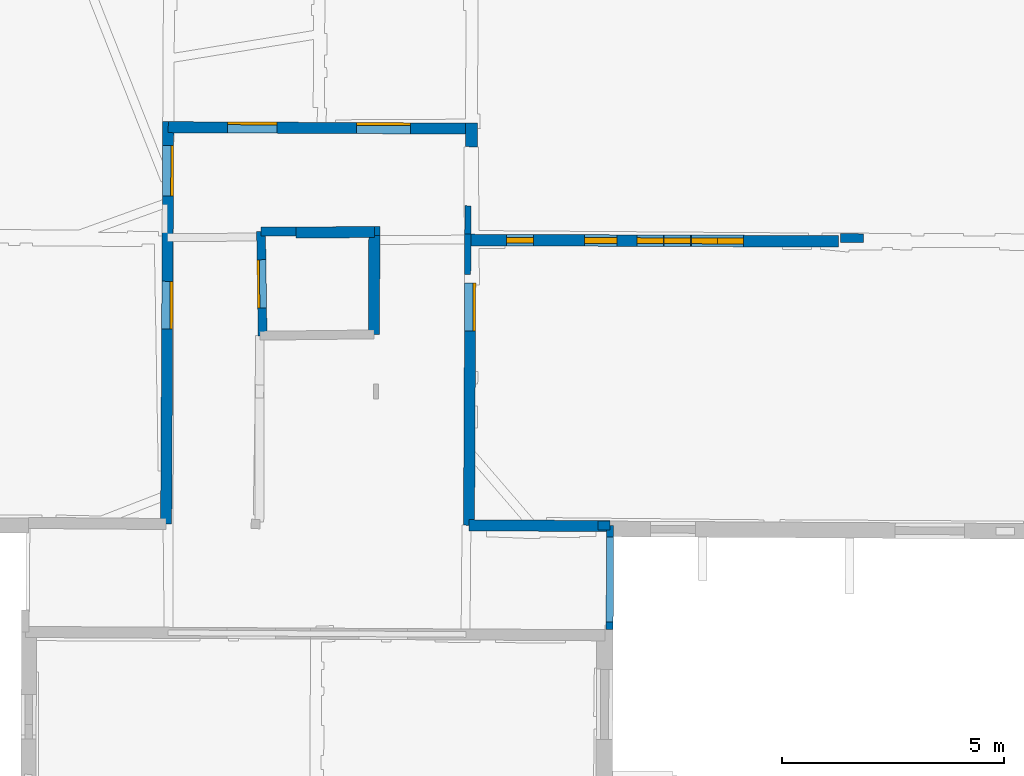
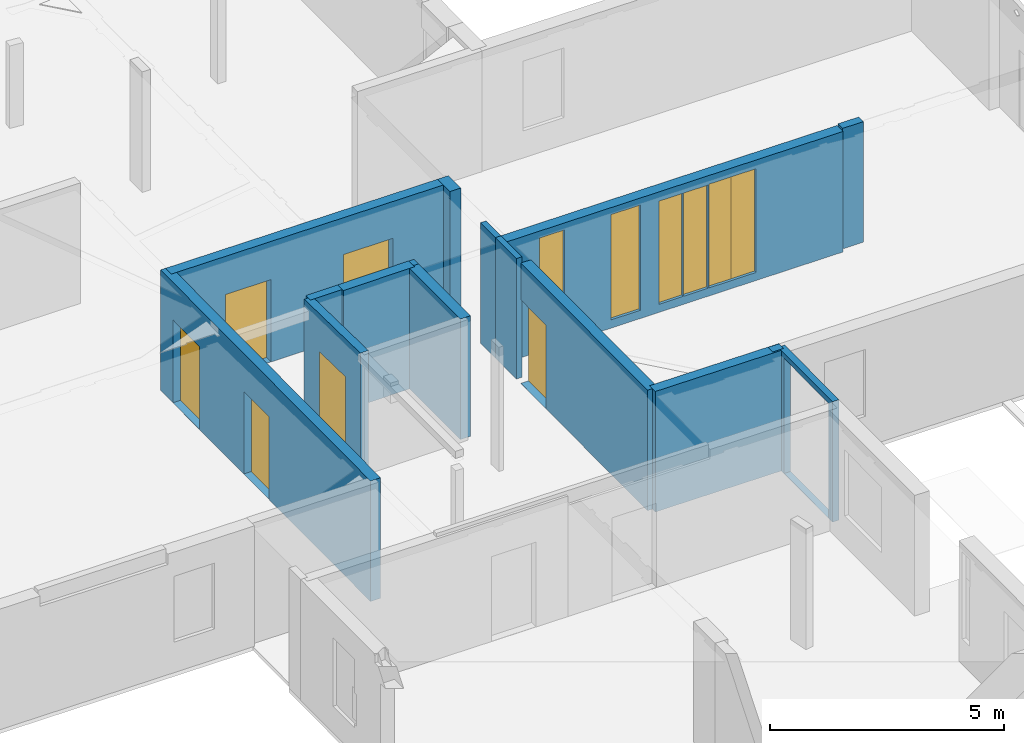
# One storey, part 7 of 14: 16 walls, 6 doors, 6 windows, 13 openings.
"""IFC2X3 building model written with IfcOpenShell, lengths in metres."""

from ifc_helpers import new_model, entity, si_unit, converted_unit, derived_unit, direction, frame, frame_2d, origin, origin_2d_with_axis, place, context, subcontext, project, spatial, polyline, rectangle, outline, extrude, source, transform, mapped, material, layer, layer_set, layer_usage, type_object, type_shapes, element, fill, save


model = new_model("IFC2X3")

# Units and contexts
model_context = context("Model", 3, precision=1e-05, world=origin(), true_north=direction((0.0, 1.0)))
body_context = subcontext(model_context, "Body", "Model", "MODEL_VIEW")
ifc_project = project(units=[si_unit("LENGTHUNIT", "METRE"), si_unit("AREAUNIT", "SQUARE_METRE"), si_unit("VOLUMEUNIT", "CUBIC_METRE"), converted_unit("PLANEANGLEUNIT", "DEGREE", entity("IfcRatioMeasure", 0.0174532925199433), si_unit("PLANEANGLEUNIT", "RADIAN"), dimensions=[0, 0, 0, 0, 0, 0, 0]), si_unit("MASSUNIT", "GRAM", prefix="KILO"), derived_unit("MASSDENSITYUNIT", [(si_unit("MASSUNIT", "GRAM", prefix="KILO"), 1), (si_unit("LENGTHUNIT", "METRE"), -3)]), derived_unit("MOMENTOFINERTIAUNIT", [(si_unit("LENGTHUNIT", "METRE"), 4)]), si_unit("TIMEUNIT", "SECOND"), si_unit("FREQUENCYUNIT", "HERTZ"), si_unit("THERMODYNAMICTEMPERATUREUNIT", "DEGREE_CELSIUS"), derived_unit("THERMALTRANSMITTANCEUNIT", [(si_unit("MASSUNIT", "GRAM", prefix="KILO"), 1), (si_unit("THERMODYNAMICTEMPERATUREUNIT", "KELVIN"), -1), (si_unit("TIMEUNIT", "SECOND"), -3)]), derived_unit("VOLUMETRICFLOWRATEUNIT", [(si_unit("LENGTHUNIT", "METRE"), 3), (si_unit("TIMEUNIT", "SECOND"), -1)]), si_unit("ELECTRICCURRENTUNIT", "AMPERE"), si_unit("ELECTRICVOLTAGEUNIT", "VOLT"), si_unit("POWERUNIT", "WATT"), si_unit("FORCEUNIT", "NEWTON", prefix="KILO"), si_unit("ILLUMINANCEUNIT", "LUX"), si_unit("LUMINOUSFLUXUNIT", "LUMEN"), si_unit("LUMINOUSINTENSITYUNIT", "CANDELA"), derived_unit("USERDEFINED", [(si_unit("MASSUNIT", "GRAM", prefix="KILO"), -1), (si_unit("LENGTHUNIT", "METRE"), -2), (si_unit("TIMEUNIT", "SECOND"), 3), (si_unit("LUMINOUSFLUXUNIT", "LUMEN"), 1)]), derived_unit("LINEARVELOCITYUNIT", [(si_unit("LENGTHUNIT", "METRE"), 1), (si_unit("TIMEUNIT", "SECOND"), -1)]), si_unit("PRESSUREUNIT", "PASCAL"), derived_unit("USERDEFINED", [(si_unit("LENGTHUNIT", "METRE"), -2), (si_unit("MASSUNIT", "GRAM", prefix="KILO"), 1), (si_unit("TIMEUNIT", "SECOND"), -2)]), derived_unit("LINEARFORCEUNIT", [(si_unit("MASSUNIT", "GRAM", prefix="KILO"), 1), (si_unit("LENGTHUNIT", "METRE"), 1), (si_unit("TIMEUNIT", "SECOND"), -2), (si_unit("LENGTHUNIT", "METRE"), -1)]), derived_unit("PLANARFORCEUNIT", [(si_unit("MASSUNIT", "GRAM", prefix="KILO"), 1), (si_unit("LENGTHUNIT", "METRE"), 1), (si_unit("TIMEUNIT", "SECOND"), -2), (si_unit("LENGTHUNIT", "METRE"), -2)])], contexts=[model_context])

# Site, building, storey
placement = place(None, origin())
site = spatial("IfcSite", under=ifc_project, at=placement, CompositionType="ELEMENT")
building = spatial("IfcBuilding", under=site, at=placement, CompositionType="ELEMENT")
storey_placement = place(placement, frame((0.0, 0.0, 8.83152770996094)))
storey = spatial("IfcBuildingStorey", under=building, at=storey_placement, Name="Level 4", CompositionType="ELEMENT", Elevation=8.83152770996094)

# Wall, openings, doors
ifc_material_1 = material(Name="Default wall")
ifc_layer_1 = layer(ifc_material_1, 0.25)
ifc_layer_set_1 = layer_set([ifc_layer_1], Name="wall_thickness_0.2500")
ifc_layer_usage_1 = layer_usage(ifc_layer_set_1, "AXIS2", "POSITIVE", -0.125)
wall_type_1 = type_object("IfcWallType", Name="wall_thickness_0.2500", PredefinedType="STANDARD", material=ifc_layer_set_1)
wall_1_placement = place(storey_placement, frame((2.97993654286292, 60.15967701383, 0.0), z_axis=(0.0, 0.0, 1.0), x_axis=(0.999988670407602, -0.00476015298446692, 0.0)))
wall_1 = element("IfcWallStandardCase", 1, at=wall_1_placement, inside=storey, type_object=wall_type_1, material=ifc_layer_usage_1, Name="Wall:388", ObjectType="Wall", context=body_context, shape_type="SweptSolid", body=[
    extrude(outline(polyline([(6.82937086344439, -0.125), (6.82937086344439, 0.125), (0.0, 0.125), (0.0, -0.125), (6.82937086344439, -0.125)])), origin(), (0.0, 0.0, 1.0), 3.14668312072754),
])
opening_1_placement = place(wall_1_placement, frame((1.33312031191429, -0.125, 0.00547218322753906)))
opening_1 = element("IfcOpeningElement", 2, at=opening_1_placement, cuts=wall_1, Name="Opening : 1120 x 2145 : 311", ObjectType="Opening", context=body_context, shape_type="SweptSolid", body=[
    extrude(rectangle(XDim=1.12, YDim=2.145, at=frame_2d((1.0725, 0.56), x_axis=(0.0, 1.0))), frame((0.0, 0.0, 0.0), z_axis=(0.0, 1.0, 0.0), x_axis=(0.0, 0.0, 1.0)), (0.0, 0.0, 1.0), 0.25),
])
opening_2_placement = place(wall_1_placement, frame((4.24312071748149, -0.125, 0.00547218322753906)))
opening_2 = element("IfcOpeningElement", 3, at=opening_2_placement, cuts=wall_1, Name="Opening : 1210 x 2180 : 312", ObjectType="Opening", context=body_context, shape_type="SweptSolid", body=[
    extrude(rectangle(XDim=1.21, YDim=2.18, at=frame_2d((1.09, 0.605), x_axis=(0.0, 1.0))), frame((0.0, 0.0, 0.0), z_axis=(0.0, 1.0, 0.0), x_axis=(0.0, 0.0, 1.0)), (0.0, 0.0, 1.0), 0.25),
])
ifc_material_2 = material(Name="Door Panel")
door_style_1 = type_object("IfcDoorStyle", Name="Door : 1120 x 2145mm", ConstructionType="NOTDEFINED", OperationType="SINGLE_SWING_RIGHT", ParameterTakesPrecedence=False, Sizeable=False, material=ifc_material_2)
shared_shape_1 = source(origin(), body_context, "Body", "SweptSolid", [
    extrude(rectangle(XDim=0.0625, YDim=1.12, at=origin_2d_with_axis()), frame((0.56, 0.21875, 0.0), z_axis=(0.0, 0.0, 1.0), x_axis=(0.0, 1.0, 0.0)), (0.0, 0.0, 1.0), 2.145),
])
type_shapes(door_style_1, [shared_shape_1])
door_1_placement = place(opening_1_placement, origin())
door_1 = element("IfcDoor", 4, at=door_1_placement, inside=storey, type_object=door_style_1, Name="Door : 1120 x 2145mm : 59", ObjectType="Door : 1120 x 2145mm", OverallHeight=2.145, OverallWidth=1.12, context=body_context, shape_type="MappedRepresentation", body=[
    mapped(shared_shape_1, transform((0.0, 0.0, 0.0), scale=1.0)),
])
fill(opening_1, door_1)
door_style_2 = type_object("IfcDoorStyle", Name="Door : 1210 x 2180mm", ConstructionType="NOTDEFINED", OperationType="SINGLE_SWING_RIGHT", ParameterTakesPrecedence=False, Sizeable=False, material=ifc_material_2)
shared_shape_2 = source(origin(), body_context, "Body", "SweptSolid", [
    extrude(rectangle(XDim=0.0625, YDim=1.21, at=origin_2d_with_axis()), frame((0.605, 0.21875, 0.0), z_axis=(0.0, 0.0, 1.0), x_axis=(0.0, 1.0, 0.0)), (0.0, 0.0, 1.0), 2.18),
])
type_shapes(door_style_2, [shared_shape_2])
door_2_placement = place(opening_2_placement, origin())
door_2 = element("IfcDoor", 5, at=door_2_placement, inside=storey, type_object=door_style_2, Name="Door : 1210 x 2180mm : 60", ObjectType="Door : 1210 x 2180mm", OverallHeight=2.18, OverallWidth=1.21, context=body_context, shape_type="MappedRepresentation", body=[
    mapped(shared_shape_2, transform((0.0, 0.0, 0.0), scale=1.0)),
])
fill(opening_2, door_2)

# Wall
wall_2_placement = place(storey_placement, frame((9.75449950184054, 51.1931051464157, 0.0), z_axis=(0.0, 0.0, 1.0), x_axis=(0.999980348594832, -0.00626916455027329, 0.0)))
element("IfcWallStandardCase", 6, at=wall_2_placement, inside=storey, type_object=wall_type_1, material=ifc_layer_usage_1, Name="Wall:418", ObjectType="Wall", context=body_context, shape_type="SweptSolid", body=[
    extrude(outline(polyline([(3.17872953498346, -0.125), (3.17872953498346, 0.125), (0.0, 0.125), (0.0, -0.125), (3.17872953498346, -0.125)])), origin(), (0.0, 0.0, 1.0), 3.14668312072754),
])

# Wall, opening, door
wall_3_placement = place(storey_placement, frame((9.7818454333714, 56.6549451362914, 0.0), z_axis=(0.0, 0.0, 1.0), x_axis=(-0.00500660722327375, -0.999987466863516, 0.0)))
wall_3 = element("IfcWallStandardCase", 7, at=wall_3_placement, inside=storey, type_object=wall_type_1, material=ifc_layer_usage_1, Name="Wall:455", ObjectType="Wall", context=body_context, shape_type="SweptSolid", body=[
    extrude(outline(polyline([(5.461913852861, -0.125), (5.461913852861, 0.125), (0.0, 0.125), (0.0, -0.125), (5.461913852861, -0.125)])), origin(), (0.0, 0.0, 1.0), 3.14668312072754),
])
opening_3_placement = place(wall_3_placement, frame((-2.16926929090056e-08, -0.125, 0.00547218322753906)))
opening_3 = element("IfcOpeningElement", 8, at=opening_3_placement, cuts=wall_3, Name="Opening : 1085 x 2180 : 351", ObjectType="Opening", context=body_context, shape_type="SweptSolid", body=[
    extrude(rectangle(XDim=1.085, YDim=2.18, at=frame_2d((1.09, 0.5425), x_axis=(0.0, 1.0))), frame((0.0, 0.0, 0.0), z_axis=(0.0, 1.0, 0.0), x_axis=(0.0, 0.0, 1.0)), (0.0, 0.0, 1.0), 0.25),
])
door_style_3 = type_object("IfcDoorStyle", Name="Door : 1085 x 2180mm", ConstructionType="NOTDEFINED", OperationType="SINGLE_SWING_RIGHT", ParameterTakesPrecedence=False, Sizeable=False, material=ifc_material_2)
shared_shape_3 = source(origin(), body_context, "Body", "SweptSolid", [
    extrude(rectangle(XDim=0.0625, YDim=1.085, at=origin_2d_with_axis()), frame((0.5425, 0.21875, 0.0), z_axis=(0.0, 0.0, 1.0), x_axis=(0.0, 1.0, 0.0)), (0.0, 0.0, 1.0), 2.18),
])
type_shapes(door_style_3, [shared_shape_3])
door_3_placement = place(opening_3_placement, origin())
door_3 = element("IfcDoor", 9, at=door_3_placement, inside=storey, type_object=door_style_3, Name="Door : 1085 x 2180mm : 67", ObjectType="Door : 1085 x 2180mm", OverallHeight=2.18, OverallWidth=1.085, context=body_context, shape_type="MappedRepresentation", body=[
    mapped(shared_shape_3, transform((0.0, 0.0, 0.0), scale=1.0)),
])
fill(opening_3, door_3)

# Wall
wall_4_placement = place(storey_placement, frame((5.85365022321484, 57.7850229386726, 0.0), z_axis=(0.0, 0.0, 1.0), x_axis=(0.99997111015831, 0.00760123994863184, 0.0)))
element("IfcWallStandardCase", 10, at=wall_4_placement, inside=storey, type_object=wall_type_1, material=ifc_layer_usage_1, Name="Wall:470", ObjectType="Wall", context=body_context, shape_type="SweptSolid", body=[
    extrude(outline(polyline([(1.76802450095209, -0.125), (1.76802450095209, 0.125), (0.0, 0.125), (0.0, -0.125), (1.76802450095209, -0.125)])), origin(), (0.0, 0.0, 1.0), 3.14668312072754),
])

# Wall, openings, doors
wall_5_placement = place(storey_placement, frame((2.98060500747895, 60.2846768660753, 0.0), z_axis=(0.0, 0.0, 1.0), x_axis=(-0.00535069657418409, -0.999985684920625, 0.0)))
wall_5 = element("IfcWallStandardCase", 11, at=wall_5_placement, inside=storey, type_object=wall_type_1, material=ifc_layer_usage_1, Name="Wall:498", ObjectType="Wall", context=body_context, shape_type="SweptSolid", body=[
    extrude(outline(polyline([(9.06358342023249, -0.125), (9.06358342023249, 0.125), (0.0, 0.125), (0.0, -0.125), (9.06358342023249, -0.125)])), origin(), (0.0, 0.0, 1.0), 3.14668312072754),
])
opening_4_placement = place(wall_5_placement, frame((0.535507241343888, -0.125, 0.00547218322753906)))
opening_4 = element("IfcOpeningElement", 12, at=opening_4_placement, cuts=wall_5, Name="Opening : 1135 x 2160 : 387", ObjectType="Opening", context=body_context, shape_type="SweptSolid", body=[
    extrude(rectangle(XDim=1.135, YDim=2.16, at=frame_2d((1.08, 0.5675), x_axis=(0.0, 1.0))), frame((0.0, 0.0, 0.0), z_axis=(0.0, 1.0, 0.0), x_axis=(0.0, 0.0, 1.0)), (0.0, 0.0, 1.0), 0.25),
])
opening_5_placement = place(wall_5_placement, frame((3.5956363442357, -0.125, 0.00547218322753906)))
opening_5 = element("IfcOpeningElement", 13, at=opening_5_placement, cuts=wall_5, Name="Opening : 1075 x 2150 : 388", ObjectType="Opening", context=body_context, shape_type="SweptSolid", body=[
    extrude(rectangle(XDim=1.075, YDim=2.15, at=frame_2d((1.075, 0.5375), x_axis=(0.0, 1.0))), frame((0.0, 0.0, 0.0), z_axis=(0.0, 1.0, 0.0), x_axis=(0.0, 0.0, 1.0)), (0.0, 0.0, 1.0), 0.25),
])
door_style_4 = type_object("IfcDoorStyle", Name="Door : 1135 x 2160mm", ConstructionType="NOTDEFINED", OperationType="SINGLE_SWING_RIGHT", ParameterTakesPrecedence=False, Sizeable=False, material=ifc_material_2)
shared_shape_4 = source(origin(), body_context, "Body", "SweptSolid", [
    extrude(rectangle(XDim=0.0625, YDim=1.135, at=origin_2d_with_axis()), frame((0.5675, 0.21875, 0.0), z_axis=(0.0, 0.0, 1.0), x_axis=(0.0, 1.0, 0.0)), (0.0, 0.0, 1.0), 2.16),
])
type_shapes(door_style_4, [shared_shape_4])
door_4_placement = place(opening_4_placement, origin())
door_4 = element("IfcDoor", 14, at=door_4_placement, inside=storey, type_object=door_style_4, Name="Door : 1135 x 2160mm : 71", ObjectType="Door : 1135 x 2160mm", OverallHeight=2.16, OverallWidth=1.135, context=body_context, shape_type="MappedRepresentation", body=[
    mapped(shared_shape_4, transform((0.0, 0.0, 0.0), scale=1.0)),
])
fill(opening_4, door_4)
door_style_5 = type_object("IfcDoorStyle", Name="Door : 1075 x 2150mm", ConstructionType="NOTDEFINED", OperationType="SINGLE_SWING_RIGHT", ParameterTakesPrecedence=False, Sizeable=False, material=ifc_material_2)
shared_shape_5 = source(origin(), body_context, "Body", "SweptSolid", [
    extrude(rectangle(XDim=0.0625, YDim=1.075, at=origin_2d_with_axis()), frame((0.5375, 0.21875, 0.0), z_axis=(0.0, 0.0, 1.0), x_axis=(0.0, 1.0, 0.0)), (0.0, 0.0, 1.0), 2.15),
])
type_shapes(door_style_5, [shared_shape_5])
door_5_placement = place(opening_5_placement, origin())
door_5 = element("IfcDoor", 15, at=door_5_placement, inside=storey, type_object=door_style_5, Name="Door : 1075 x 2150mm : 72", ObjectType="Door : 1075 x 2150mm", OverallHeight=2.15, OverallWidth=1.075, context=body_context, shape_type="MappedRepresentation", body=[
    mapped(shared_shape_5, transform((0.0, 0.0, 0.0), scale=1.0)),
])
fill(opening_5, door_5)

# Walls
wall_6_placement = place(storey_placement, frame((7.6216798637633, 57.8204709033812, 0.0), z_axis=(0.0, 0.0, 1.0), x_axis=(-0.00251700841805289, -0.999996832329295, 0.0)))
element("IfcWallStandardCase", 16, at=wall_6_placement, inside=storey, type_object=wall_type_1, material=ifc_layer_usage_1, Name="Wall:500", ObjectType="Wall", context=body_context, shape_type="SweptSolid", body=[
    extrude(outline(polyline([(2.32753346538887, -0.125), (2.32753346538887, 0.125), (0.0, 0.125), (0.0, -0.125), (2.32753346538887, -0.125)])), origin(), (0.0, 0.0, 1.0), 3.14668312072754),
])
ifc_layer_2 = layer(ifc_material_1, 0.2)
ifc_layer_set_2 = layer_set([ifc_layer_2], Name="wall_thickness_0.2000")
ifc_layer_usage_2 = layer_usage(ifc_layer_set_2, "AXIS2", "POSITIVE", -0.1)
wall_type_2 = type_object("IfcWallType", Name="wall_thickness_0.2000", PredefinedType="STANDARD", material=ifc_layer_set_2)
wall_7_placement = place(storey_placement, frame((18.1231795934543, 57.6606397762186, 0.0), z_axis=(0.0, 0.0, 1.0), x_axis=(0.999994144552583, -0.00342211346211982, 0.0)))
element("IfcWallStandardCase", 17, at=wall_7_placement, inside=storey, type_object=wall_type_2, material=ifc_layer_usage_2, Name="Wall:380", ObjectType="Wall", context=body_context, shape_type="SweptSolid", body=[
    extrude(outline(polyline([(0.51500049785814, -0.1), (0.51500049785814, 0.1), (0.0, 0.1), (0.0, -0.1), (0.51500049785814, -0.1)])), origin(), (0.0, 0.0, 1.0), 3.14668312072754),
])

# Wall, opening, door
wall_8_placement = place(storey_placement, frame((5.10455516830078, 55.4626683456325, 0.0), z_axis=(0.0, 0.0, 1.0), x_axis=(-0.0145237256227784, 0.999894525134544, 0.0)))
wall_8 = element("IfcWallStandardCase", 18, at=wall_8_placement, inside=storey, type_object=wall_type_2, material=ifc_layer_usage_2, Name="Wall:459", ObjectType="Wall", context=body_context, shape_type="SweptSolid", body=[
    extrude(outline(polyline([(2.34342115274368, -0.1), (2.34342115274368, 0.1), (0.0, 0.1), (0.0, -0.1), (2.34342115274368, -0.1)])), origin(), (0.0, 0.0, 1.0), 3.14668312072754),
])
opening_6_placement = place(wall_8_placement, frame((0.626176127005285, -0.1, 0.00547218322753906)))
opening_6 = element("IfcOpeningElement", 19, at=opening_6_placement, cuts=wall_8, Name="Opening : 1085 x 2150 : 353", ObjectType="Opening", context=body_context, shape_type="SweptSolid", body=[
    extrude(rectangle(XDim=1.085, YDim=2.15, at=frame_2d((1.075, 0.5425), x_axis=(0.0, 1.0))), frame((0.0, 0.0, 0.0), z_axis=(0.0, 1.0, 0.0), x_axis=(0.0, 0.0, 1.0)), (0.0, 0.0, 1.0), 0.2),
])
door_style_6 = type_object("IfcDoorStyle", Name="Door : 1085 x 2150mm", ConstructionType="NOTDEFINED", OperationType="SINGLE_SWING_RIGHT", ParameterTakesPrecedence=False, Sizeable=False, material=ifc_material_2)
shared_shape_6 = source(origin(), body_context, "Body", "SweptSolid", [
    extrude(rectangle(XDim=0.05, YDim=1.085, at=origin_2d_with_axis()), frame((0.5425, 0.175, 0.0), z_axis=(0.0, 0.0, 1.0), x_axis=(0.0, 1.0, 0.0)), (0.0, 0.0, 1.0), 2.15),
])
type_shapes(door_style_6, [shared_shape_6])
door_6_placement = place(opening_6_placement, origin())
door_6 = element("IfcDoor", 20, at=door_6_placement, inside=storey, type_object=door_style_6, Name="Door : 1085 x 2150mm : 68", ObjectType="Door : 1085 x 2150mm", OverallHeight=2.15, OverallWidth=1.085, context=body_context, shape_type="MappedRepresentation", body=[
    mapped(shared_shape_6, transform((0.0, 0.0, 0.0), scale=1.0)),
])
fill(opening_6, door_6)

# Walls
wall_9_placement = place(storey_placement, frame((5.07052006826154, 57.8058396560868, 0.0), z_axis=(0.0, 0.0, 1.0), x_axis=(0.999983540968603, 0.00573740288755389, 0.0)))
element("IfcWallStandardCase", 21, at=wall_9_placement, inside=storey, type_object=wall_type_2, material=ifc_layer_usage_2, Name="Wall:490", ObjectType="Wall", context=body_context, shape_type="SweptSolid", body=[
    extrude(outline(polyline([(0.783231275017209, -0.1), (0.783231275017209, 0.1), (0.0, 0.1), (0.0, -0.1), (0.783231275017209, -0.1)])), origin(), (0.0, 0.0, 1.0), 3.14668312072754),
])
wall_10_placement = place(storey_placement, frame((7.62167992696516, 57.8204690201005, 0.0), z_axis=(0.0, 0.0, 1.0), x_axis=(0.999983571012362, 0.00573216410828986, 0.0)))
element("IfcWallStandardCase", 22, at=wall_10_placement, inside=storey, type_object=wall_type_2, material=ifc_layer_usage_2, Name="Wall:491", ObjectType="Wall", context=body_context, shape_type="SweptSolid", body=[
    extrude(outline(polyline([(0.126443079223875, -0.1), (0.126443079223875, 0.1), (0.0, 0.1), (0.0, -0.1), (0.126443079223875, -0.1)])), origin(), (0.0, 0.0, 1.0), 3.14668312072754),
])

# Wall, openings, windows
ifc_layer_3 = layer(ifc_material_1, 0.259999990463257)
ifc_layer_set_3 = layer_set([ifc_layer_3], Name="wall_thickness_0.2600")
ifc_layer_usage_3 = layer_usage(ifc_layer_set_3, "AXIS2", "POSITIVE", -0.129999995231628)
wall_type_3 = type_object("IfcWallType", Name="wall_thickness_0.2600", PredefinedType="STANDARD", material=ifc_layer_set_3)
wall_11_placement = place(storey_placement, frame((9.72732524789789, 57.6185894595848, 0.0), z_axis=(0.0, 0.0, 1.0), x_axis=(0.999993131088428, -0.00370645058800741, 0.0)))
wall_11 = element("IfcWallStandardCase", 23, at=wall_11_placement, inside=storey, type_object=wall_type_3, material=ifc_layer_usage_3, Name="Wall:501", ObjectType="Wall", context=body_context, shape_type="SweptSolid", body=[
    extrude(outline(polyline([(8.35405652115393, -0.129999995231628), (8.35405652115393, 0.129999995231628), (0.0, 0.129999995231628), (0.0, -0.129999995231628), (8.35405652115393, -0.129999995231628)])), origin(), (0.0, 0.0, 1.0), 3.14668312072754),
])
opening_7_placement = place(wall_11_placement, frame((0.872694247425188, -0.129999995231628, 0.22047233581543)))
opening_7 = element("IfcOpeningElement", 24, at=opening_7_placement, cuts=wall_11, Name="Opening : 610 x 2745 : 391", ObjectType="Opening", context=body_context, shape_type="SweptSolid", body=[
    extrude(rectangle(XDim=0.61, YDim=2.745, at=frame_2d((1.3725, 0.305), x_axis=(0.0, 1.0))), frame((0.0, 0.0, 0.0), z_axis=(0.0, 1.0, 0.0), x_axis=(0.0, 0.0, 1.0)), (0.0, 0.0, 1.0), 0.259999990463257),
])
opening_8_placement = place(wall_11_placement, frame((2.62769498402401, -0.129999995231628, 0.215472221374512)))
opening_8 = element("IfcOpeningElement", 25, at=opening_8_placement, cuts=wall_11, Name="Opening : 730 x 2750 : 392", ObjectType="Opening", context=body_context, shape_type="SweptSolid", body=[
    extrude(rectangle(XDim=0.73, YDim=2.75, at=frame_2d((1.375, 0.365), x_axis=(0.0, 1.0))), frame((0.0, 0.0, 0.0), z_axis=(0.0, 1.0, 0.0), x_axis=(0.0, 0.0, 1.0)), (0.0, 0.0, 1.0), 0.259999990463257),
])
opening_9_placement = place(wall_11_placement, frame((5.0426943614994, -0.129999995231628, 0.210472106933594)))
opening_9 = element("IfcOpeningElement", 26, at=opening_9_placement, cuts=wall_11, Name="Opening : 585 x 2710 : 393", ObjectType="Opening", context=body_context, shape_type="SweptSolid", body=[
    extrude(rectangle(XDim=0.585, YDim=2.71, at=frame_2d((1.355, 0.2925), x_axis=(0.0, 1.0))), frame((0.0, 0.0, 0.0), z_axis=(0.0, 1.0, 0.0), x_axis=(0.0, 0.0, 1.0)), (0.0, 0.0, 1.0), 0.259999990463257),
])
opening_10_placement = place(wall_11_placement, frame((5.62269446095483, -0.129999995231628, 0.210472106933594)))
opening_10 = element("IfcOpeningElement", 27, at=opening_10_placement, cuts=wall_11, Name="Opening : 585 x 2710 : 394", ObjectType="Opening", context=body_context, shape_type="SweptSolid", body=[
    extrude(rectangle(XDim=0.585, YDim=2.71, at=frame_2d((1.355, 0.2925), x_axis=(0.0, 1.0))), frame((0.0, 0.0, 0.0), z_axis=(0.0, 1.0, 0.0), x_axis=(0.0, 0.0, 1.0)), (0.0, 0.0, 1.0), 0.259999990463257),
])
opening_11_placement = place(wall_11_placement, frame((3.81269495494168, -0.129999995231628, 0.210472106933594)))
opening_11 = element("IfcOpeningElement", 28, at=opening_11_placement, cuts=wall_11, Name="Opening : 595 x 2695 : 395", ObjectType="Opening", context=body_context, shape_type="SweptSolid", body=[
    extrude(rectangle(XDim=0.595, YDim=2.695, at=frame_2d((1.3475, 0.2975), x_axis=(0.0, 1.0))), frame((0.0, 0.0, 0.0), z_axis=(0.0, 1.0, 0.0), x_axis=(0.0, 0.0, 1.0)), (0.0, 0.0, 1.0), 0.259999990463257),
])
opening_12_placement = place(wall_11_placement, frame((4.4176948405429, -0.129999995231628, 0.210472106933594)))
opening_12 = element("IfcOpeningElement", 29, at=opening_12_placement, cuts=wall_11, Name="Opening : 600 x 2695 : 396", ObjectType="Opening", context=body_context, shape_type="SweptSolid", body=[
    extrude(rectangle(XDim=0.6, YDim=2.695, at=frame_2d((1.3475, 0.3), x_axis=(0.0, 1.0))), frame((0.0, 0.0, 0.0), z_axis=(0.0, 1.0, 0.0), x_axis=(0.0, 0.0, 1.0)), (0.0, 0.0, 1.0), 0.259999990463257),
])
ifc_material_3 = material(Name="Window Default")
window_style_1 = type_object("IfcWindowStyle", Name="Window : 610 x 2745mm", ConstructionType="NOTDEFINED", OperationType="NOTDEFINED", ParameterTakesPrecedence=False, Sizeable=False, material=ifc_material_3)
shared_shape_7 = source(origin(), body_context, "Body", "SweptSolid", [
    extrude(rectangle(XDim=0.129999995231628, YDim=0.61, at=origin_2d_with_axis()), frame((0.305, 0.129999995231628, 0.0), z_axis=(0.0, 0.0, 1.0), x_axis=(0.0, 1.0, 0.0)), (0.0, 0.0, 1.0), 2.745),
])
type_shapes(window_style_1, [shared_shape_7])
window_1_placement = place(opening_7_placement, origin())
window_1 = element("IfcWindow", 30, at=window_1_placement, inside=storey, type_object=window_style_1, Name="Window : 610 x 2745mm : 214", ObjectType="Window : 610 x 2745mm", OverallHeight=2.745, OverallWidth=0.61, context=body_context, shape_type="MappedRepresentation", body=[
    mapped(shared_shape_7, transform((0.0, 0.0, 0.0), scale=1.0)),
])
fill(opening_7, window_1)
window_style_2 = type_object("IfcWindowStyle", Name="Window : 730 x 2750mm", ConstructionType="NOTDEFINED", OperationType="NOTDEFINED", ParameterTakesPrecedence=False, Sizeable=False, material=ifc_material_3)
shared_shape_8 = source(origin(), body_context, "Body", "SweptSolid", [
    extrude(rectangle(XDim=0.129999995231628, YDim=0.73, at=origin_2d_with_axis()), frame((0.365, 0.129999995231628, 0.0), z_axis=(0.0, 0.0, 1.0), x_axis=(0.0, 1.0, 0.0)), (0.0, 0.0, 1.0), 2.75),
])
type_shapes(window_style_2, [shared_shape_8])
window_2_placement = place(opening_8_placement, origin())
window_2 = element("IfcWindow", 31, at=window_2_placement, inside=storey, type_object=window_style_2, Name="Window : 730 x 2750mm : 215", ObjectType="Window : 730 x 2750mm", OverallHeight=2.75, OverallWidth=0.73, context=body_context, shape_type="MappedRepresentation", body=[
    mapped(shared_shape_8, transform((0.0, 0.0, 0.0), scale=1.0)),
])
fill(opening_8, window_2)
window_style_3 = type_object("IfcWindowStyle", Name="Window : 585 x 2710mm", ConstructionType="NOTDEFINED", OperationType="NOTDEFINED", ParameterTakesPrecedence=False, Sizeable=False, material=ifc_material_3)
shared_shape_9 = source(origin(), body_context, "Body", "SweptSolid", [
    extrude(rectangle(XDim=0.129999995231628, YDim=0.585, at=origin_2d_with_axis()), frame((0.2925, 0.129999995231628, 0.0), z_axis=(0.0, 0.0, 1.0), x_axis=(0.0, 1.0, 0.0)), (0.0, 0.0, 1.0), 2.71),
])
type_shapes(window_style_3, [shared_shape_9])
window_3_placement = place(opening_9_placement, origin())
window_3 = element("IfcWindow", 32, at=window_3_placement, inside=storey, type_object=window_style_3, Name="Window : 585 x 2710mm : 216", ObjectType="Window : 585 x 2710mm", OverallHeight=2.71, OverallWidth=0.585, context=body_context, shape_type="MappedRepresentation", body=[
    mapped(shared_shape_9, transform((0.0, 0.0, 0.0), scale=1.0)),
])
fill(opening_9, window_3)
window_4_placement = place(opening_10_placement, origin())
window_4 = element("IfcWindow", 33, at=window_4_placement, inside=storey, type_object=window_style_3, Name="Window : 585 x 2710mm : 217", ObjectType="Window : 585 x 2710mm", OverallHeight=2.71, OverallWidth=0.585, context=body_context, shape_type="MappedRepresentation", body=[
    mapped(shared_shape_9, transform((0.0, 0.0, 0.0), scale=1.0)),
])
fill(opening_10, window_4)
window_style_4 = type_object("IfcWindowStyle", Name="Window : 595 x 2695mm", ConstructionType="NOTDEFINED", OperationType="NOTDEFINED", ParameterTakesPrecedence=False, Sizeable=False, material=ifc_material_3)
shared_shape_10 = source(origin(), body_context, "Body", "SweptSolid", [
    extrude(rectangle(XDim=0.129999995231628, YDim=0.595, at=origin_2d_with_axis()), frame((0.2975, 0.129999995231628, 0.0), z_axis=(0.0, 0.0, 1.0), x_axis=(0.0, 1.0, 0.0)), (0.0, 0.0, 1.0), 2.695),
])
type_shapes(window_style_4, [shared_shape_10])
window_5_placement = place(opening_11_placement, origin())
window_5 = element("IfcWindow", 34, at=window_5_placement, inside=storey, type_object=window_style_4, Name="Window : 595 x 2695mm : 218", ObjectType="Window : 595 x 2695mm", OverallHeight=2.695, OverallWidth=0.595, context=body_context, shape_type="MappedRepresentation", body=[
    mapped(shared_shape_10, transform((0.0, 0.0, 0.0), scale=1.0)),
])
fill(opening_11, window_5)
window_style_5 = type_object("IfcWindowStyle", Name="Window : 600 x 2695mm", ConstructionType="NOTDEFINED", OperationType="NOTDEFINED", ParameterTakesPrecedence=False, Sizeable=False, material=ifc_material_3)
shared_shape_11 = source(origin(), body_context, "Body", "SweptSolid", [
    extrude(rectangle(XDim=0.129999995231628, YDim=0.6, at=origin_2d_with_axis()), frame((0.3, 0.129999995231628, 0.0), z_axis=(0.0, 0.0, 1.0), x_axis=(0.0, 1.0, 0.0)), (0.0, 0.0, 1.0), 2.695),
])
type_shapes(window_style_5, [shared_shape_11])
window_6_placement = place(opening_12_placement, origin())
window_6 = element("IfcWindow", 35, at=window_6_placement, inside=storey, type_object=window_style_5, Name="Window : 600 x 2695mm : 219", ObjectType="Window : 600 x 2695mm", OverallHeight=2.695, OverallWidth=0.6, context=body_context, shape_type="MappedRepresentation", body=[
    mapped(shared_shape_11, transform((0.0, 0.0, 0.0), scale=1.0)),
])
fill(opening_12, window_6)

# Wall, opening
ifc_layer_4 = layer(ifc_material_1, 0.159999996423721)
ifc_layer_set_4 = layer_set([ifc_layer_4], Name="wall_thickness_0.1600")
ifc_layer_usage_4 = layer_usage(ifc_layer_set_4, "AXIS2", "POSITIVE", -0.0799999982118607)
wall_type_4 = type_object("IfcWallType", Name="wall_thickness_0.1600", PredefinedType="STANDARD", material=ifc_layer_set_4)
wall_12_placement = place(storey_placement, frame((12.9332407842785, 51.1888453767054, 0.0), z_axis=(0.0, 0.0, 1.0), x_axis=(-0.00480156963902069, -0.999988472398058, 0.0)))
wall_12 = element("IfcWallStandardCase", 36, at=wall_12_placement, inside=storey, type_object=wall_type_4, material=ifc_layer_usage_4, Name="Wall:460", ObjectType="Wall", context=body_context, shape_type="SweptSolid", body=[
    extrude(outline(polyline([(2.34566912978377, -0.0799999982118607), (2.34566912978377, 0.0799999982118607), (0.0, 0.0799999982118607), (0.0, -0.0799999982118607), (2.34566912978377, -0.0799999982118607)])), origin(), (0.0, 0.0, 1.0), 3.14668312072754),
])
opening_13_placement = place(wall_12_placement, frame((0.259890636368741, -0.0799999982118607, 0.00547218322753906)))
element("IfcOpeningElement", 37, at=opening_13_placement, cuts=wall_12, Name="Opening : 1910 x 3000 : 354", ObjectType="Opening", context=body_context, shape_type="SweptSolid", body=[
    extrude(rectangle(XDim=1.91, YDim=3.0, at=frame_2d((1.5, 0.955), x_axis=(0.0, 1.0))), frame((0.0, 0.0, 0.0), z_axis=(0.0, 1.0, 0.0), x_axis=(0.0, 0.0, 1.0)), (0.0, 0.0, 1.0), 0.159999996423721),
])

# Walls
ifc_layer_5 = layer(ifc_material_1, 0.200000002980232)
ifc_layer_set_5 = layer_set([ifc_layer_5], Name="wall_thickness_0.2000")
ifc_layer_usage_5 = layer_usage(ifc_layer_set_5, "AXIS2", "POSITIVE", -0.100000001490116)
wall_type_5 = type_object("IfcWallType", Name="wall_thickness_0.2000", PredefinedType="STANDARD", material=ifc_layer_set_5)
wall_13_placement = place(storey_placement, frame((12.6642249422367, 51.191091581828, 0.0), z_axis=(0.0, 0.0, 1.0), x_axis=(0.999965123100499, -0.00835180115931288, 0.0)))
element("IfcWallStandardCase", 38, at=wall_13_placement, inside=storey, type_object=wall_type_5, material=ifc_layer_usage_5, Name="Wall:378", ObjectType="Wall", context=body_context, shape_type="SweptSolid", body=[
    extrude(outline(polyline([(0.269026602357231, -0.100000001490116), (0.269026602357231, 0.100000001490116), (0.0, 0.100000001490116), (0.0, -0.100000001490116), (0.269026602357231, -0.100000001490116)])), origin(), (0.0, 0.0, 1.0), 3.14668312072754),
])
ifc_layer_6 = layer(ifc_material_1, 0.270000010728836)
ifc_layer_set_6 = layer_set([ifc_layer_6], Name="wall_thickness_0.2700")
ifc_layer_usage_6 = layer_usage(ifc_layer_set_6, "AXIS2", "POSITIVE", -0.135000005364418)
wall_type_6 = type_object("IfcWallType", Name="wall_thickness_0.2700", PredefinedType="STANDARD", material=ifc_layer_set_6)
wall_14_placement = place(storey_placement, frame((9.80985640664393, 60.2521660557207, 0.0), z_axis=(0.0, 0.0, 1.0), x_axis=(-0.00500823072356132, -0.999987458733868, 0.0)))
element("IfcWallStandardCase", 39, at=wall_14_placement, inside=storey, type_object=wall_type_6, material=ifc_layer_usage_6, Name="Wall:454", ObjectType="Wall", context=body_context, shape_type="SweptSolid", body=[
    extrude(outline(polyline([(0.533560768676035, -0.135000005364418), (0.533560768676035, 0.135000005364418), (0.0, 0.135000005364418), (0.0, -0.135000005364418), (0.533560768676035, -0.135000005364418)])), origin(), (0.0, 0.0, 1.0), 3.14668312072754),
])
ifc_layer_7 = layer(ifc_material_1, 0.140000000596046)
ifc_layer_set_7 = layer_set([ifc_layer_7], Name="wall_thickness_0.1400")
ifc_layer_usage_7 = layer_usage(ifc_layer_set_7, "AXIS2", "POSITIVE", -0.0700000002980232)
wall_type_7 = type_object("IfcWallType", Name="wall_thickness_0.1400", PredefinedType="STANDARD", material=ifc_layer_set_7)
wall_15_placement = place(storey_placement, frame((9.7313563176656, 58.3898273623922, 0.0), z_axis=(0.0, 0.0, 1.0), x_axis=(-0.00522607781917987, -0.99998634396207, 0.0)))
element("IfcWallStandardCase", 40, at=wall_15_placement, inside=storey, type_object=wall_type_7, material=ifc_layer_usage_7, Name="Wall:416", ObjectType="Wall", context=body_context, shape_type="SweptSolid", body=[
    extrude(outline(polyline([(0.641247923165727, -0.0700000002980232), (0.641247923165727, 0.0700000002980232), (0.0, 0.0700000002980232), (0.0, -0.0700000002980232), (0.641247923165727, -0.0700000002980232)])), origin(), (0.0, 0.0, 1.0), 3.14668312072754),
])
wall_16_placement = place(storey_placement, frame((9.72800510611775, 57.7485881961324, 0.0), z_axis=(0.0, 0.0, 1.0), x_axis=(-0.00522638007152584, -0.999986342382409, 0.0)))
element("IfcWallStandardCase", 41, at=wall_16_placement, inside=storey, type_object=wall_type_7, material=ifc_layer_usage_7, Name="Wall:417", ObjectType="Wall", context=body_context, shape_type="SweptSolid", body=[
    extrude(outline(polyline([(0.904702144894288, -0.0700000002980232), (0.904702144894288, 0.0700000002980232), (0.0, 0.0700000002980232), (0.0, -0.0700000002980232), (0.904702144894288, -0.0700000002980232)])), origin(), (0.0, 0.0, 1.0), 3.14668312072754),
])

save(model, "model.ifc")
